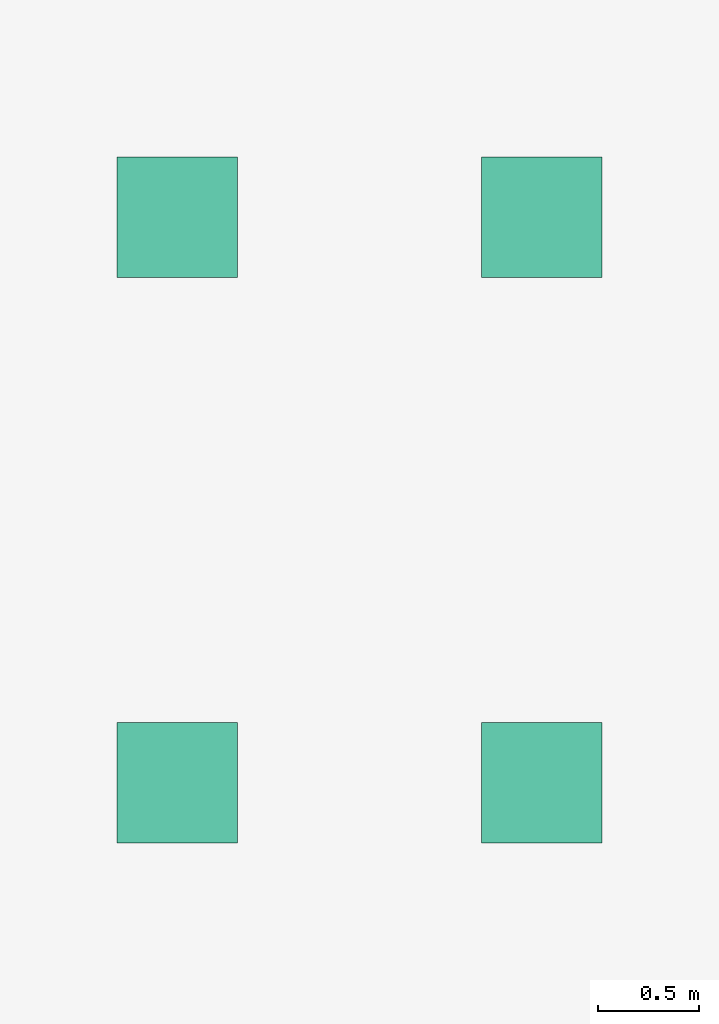
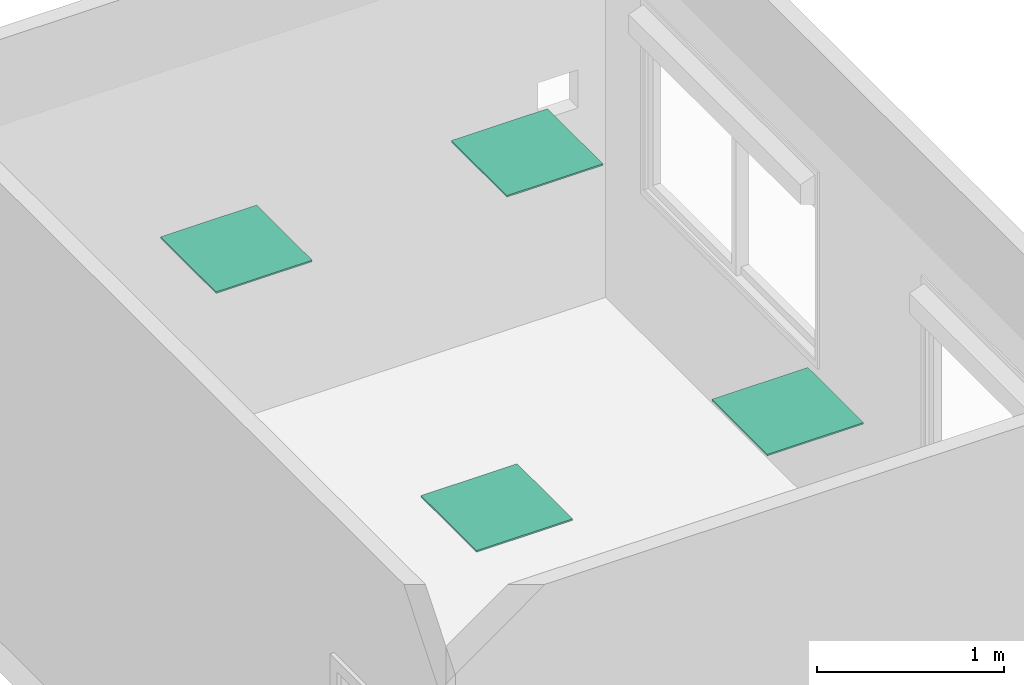
# One storey, part 3 of 3: 4 flow terminals.
"""IFC2X3 building model written with IfcOpenShell, lengths in millimetres."""

from ifc_helpers import new_model, entity, si_unit, converted_unit, derived_unit, direction, frame, origin, origin_2d_with_axis, place, context, subcontext, project, spatial, polyline, rectangle, outline, extrude, source, transform, mapped, material, material_list, type_object, type_shapes, element, save


model = new_model("IFC2X3")

# Units and contexts
model_context = context("Model", 3, precision=0.01, world=origin(), true_north=direction((6.12303176911189e-17, 1.0)))
body_context = subcontext(model_context, "Body", "Model", "MODEL_VIEW")
ifc_project = project(units=[si_unit("LENGTHUNIT", "METRE", prefix="MILLI"), si_unit("AREAUNIT", "SQUARE_METRE"), si_unit("VOLUMEUNIT", "CUBIC_METRE"), converted_unit("PLANEANGLEUNIT", "DEGREE", entity("IfcRatioMeasure", 0.0174532925199433), si_unit("PLANEANGLEUNIT", "RADIAN"), dimensions=[0, 0, 0, 0, 0, 0, 0]), si_unit("MASSUNIT", "GRAM", prefix="KILO"), derived_unit("MASSDENSITYUNIT", [(si_unit("MASSUNIT", "GRAM", prefix="KILO"), 1), (si_unit("LENGTHUNIT", "METRE"), -3)]), derived_unit("MOMENTOFINERTIAUNIT", [(si_unit("LENGTHUNIT", "METRE"), 4)]), si_unit("TIMEUNIT", "SECOND"), si_unit("FREQUENCYUNIT", "HERTZ"), si_unit("THERMODYNAMICTEMPERATUREUNIT", "DEGREE_CELSIUS"), derived_unit("THERMALTRANSMITTANCEUNIT", [(si_unit("MASSUNIT", "GRAM", prefix="KILO"), 1), (si_unit("THERMODYNAMICTEMPERATUREUNIT", "KELVIN"), -1), (si_unit("TIMEUNIT", "SECOND"), -3)]), derived_unit("VOLUMETRICFLOWRATEUNIT", [(si_unit("LENGTHUNIT", "METRE"), 3), (si_unit("TIMEUNIT", "SECOND"), -1)]), si_unit("ELECTRICCURRENTUNIT", "AMPERE"), si_unit("ELECTRICVOLTAGEUNIT", "VOLT"), si_unit("POWERUNIT", "WATT"), si_unit("FORCEUNIT", "NEWTON", prefix="KILO"), si_unit("ILLUMINANCEUNIT", "LUX"), si_unit("LUMINOUSFLUXUNIT", "LUMEN"), si_unit("LUMINOUSINTENSITYUNIT", "CANDELA"), derived_unit("USERDEFINED", [(si_unit("MASSUNIT", "GRAM", prefix="KILO"), -1), (si_unit("LENGTHUNIT", "METRE"), -2), (si_unit("TIMEUNIT", "SECOND"), 3), (si_unit("LUMINOUSFLUXUNIT", "LUMEN"), 1)]), derived_unit("LINEARVELOCITYUNIT", [(si_unit("LENGTHUNIT", "METRE"), 1), (si_unit("TIMEUNIT", "SECOND"), -1)]), si_unit("PRESSUREUNIT", "PASCAL"), derived_unit("USERDEFINED", [(si_unit("LENGTHUNIT", "METRE"), -2), (si_unit("MASSUNIT", "GRAM", prefix="KILO"), 1), (si_unit("TIMEUNIT", "SECOND"), -2)]), derived_unit("LINEARFORCEUNIT", [(si_unit("MASSUNIT", "GRAM", prefix="KILO"), 1), (si_unit("LENGTHUNIT", "METRE"), 1), (si_unit("TIMEUNIT", "SECOND"), -2), (si_unit("LENGTHUNIT", "METRE"), -1)]), derived_unit("PLANARFORCEUNIT", [(si_unit("MASSUNIT", "GRAM", prefix="KILO"), 1), (si_unit("LENGTHUNIT", "METRE"), 1), (si_unit("TIMEUNIT", "SECOND"), -2), (si_unit("LENGTHUNIT", "METRE"), -2)])], contexts=[model_context])

# Site, building, storey
site_placement = place(None, origin())
site = spatial("IfcSite", under=ifc_project, at=site_placement, CompositionType="ELEMENT")
building_placement = place(site_placement, origin())
building = spatial("IfcBuilding", under=site, at=building_placement, CompositionType="ELEMENT")
storey_placement = place(building_placement, origin())
storey = spatial("IfcBuildingStorey", under=building, at=storey_placement, Name="Niveau 1", CompositionType="ELEMENT", Elevation=0.0)

# Flow terminals
ifc_material_1 = material(Name="FAS_Aluminum, Anodized Blue")
ifc_material_2 = material(Name="FAS_Polycarbonate, Clear")
ifc_material_3 = material(Name="FAS_Aluminium")
ifc_material_list_1 = material_list([ifc_material_1, ifc_material_2, ifc_material_3])
ifc_material_list_2 = material_list([ifc_material_3, ifc_material_1])
light_fixture_type = type_object("IfcLightFixtureType", PredefinedType="NOTDEFINED", material=ifc_material_list_2)
shared_shape = source(origin(), body_context, "Body", "SweptSolid", [
    extrude(rectangle(XDim=535.000000000018, YDim=535.000000000014, at=origin_2d_with_axis()), frame((0.0, 0.0, -10.0), z_axis=(0.0, 0.0, 1.0), x_axis=(0.0, 1.0, 0.0)), (0.0, 0.0, 1.0), 4.99999999998535),
    extrude(rectangle(XDim=535.000000000018, YDim=535.000000000014, at=origin_2d_with_axis()), frame((0.0, 0.0, -5.0), z_axis=(0.0, 0.0, 1.0), x_axis=(0.0, -1.0, 0.0)), (0.0, 0.0, 1.0), 4.99999999998363),
    extrude(outline(polyline([(-297.500000000008, -297.500000000007), (297.500000000009, -297.500000000007), (297.500000000009, 297.500000000007), (-297.50000000001, 297.500000000007), (-297.500000000008, -297.500000000007)]), holes=[polyline([(267.500000000009, -267.500000000007), (-267.500000000008, -267.500000000007), (-267.50000000001, 267.500000000007), (267.500000000009, 267.500000000007), (267.500000000009, -267.500000000007)])]), frame((0.0, 0.0, -10.0), z_axis=(0.0, 0.0, 1.0), x_axis=(0.0, 1.0, 0.0)), (0.0, 0.0, 1.0), 9.99999999996899),
])
type_shapes(light_fixture_type, [shared_shape])
flow_terminal_1_placement = place(storey_placement, frame((-1227.06093937369, 2187.95257555432, 2380.0), z_axis=(0.0, 0.0, -1.0), x_axis=(1.0, 0.0, 0.0)))
element("IfcFlowTerminal", 1, at=flow_terminal_1_placement, inside=storey, type_object=light_fixture_type, material=ifc_material_list_1, context=body_context, shape_type="MappedRepresentation", body=[
    mapped(shared_shape, transform((0.0, 0.0, 0.0), scale=1.0)),
])
ifc_material_list_3 = material_list([ifc_material_1, ifc_material_2, ifc_material_3])
flow_terminal_2_placement = place(storey_placement, frame((572.939060626309, 2187.95257555432, 2380.0), z_axis=(0.0, 0.0, -1.0), x_axis=(1.0, 0.0, 0.0)))
element("IfcFlowTerminal", 2, at=flow_terminal_2_placement, inside=storey, type_object=light_fixture_type, material=ifc_material_list_3, context=body_context, shape_type="MappedRepresentation", body=[
    mapped(shared_shape, transform((0.0, 0.0, 0.0), scale=1.0)),
])
ifc_material_list_4 = material_list([ifc_material_1, ifc_material_2, ifc_material_3])
flow_terminal_3_placement = place(storey_placement, frame((-1227.0609393739, -604.547424445675, 2380.0), z_axis=(0.0, 0.0, -1.0), x_axis=(1.0, 0.0, 0.0)))
element("IfcFlowTerminal", 3, at=flow_terminal_3_placement, inside=storey, type_object=light_fixture_type, material=ifc_material_list_4, context=body_context, shape_type="MappedRepresentation", body=[
    mapped(shared_shape, transform((0.0, 0.0, 0.0), scale=1.0)),
])
ifc_material_list_5 = material_list([ifc_material_1, ifc_material_2, ifc_material_3])
flow_terminal_4_placement = place(storey_placement, frame((572.939060626313, -604.547424445675, 2380.0), z_axis=(0.0, 0.0, -1.0), x_axis=(1.0, 0.0, 0.0)))
element("IfcFlowTerminal", 4, at=flow_terminal_4_placement, inside=storey, type_object=light_fixture_type, material=ifc_material_list_5, context=body_context, shape_type="MappedRepresentation", body=[
    mapped(shared_shape, transform((0.0, 0.0, 0.0), scale=1.0)),
])

save(model, "model.ifc")
